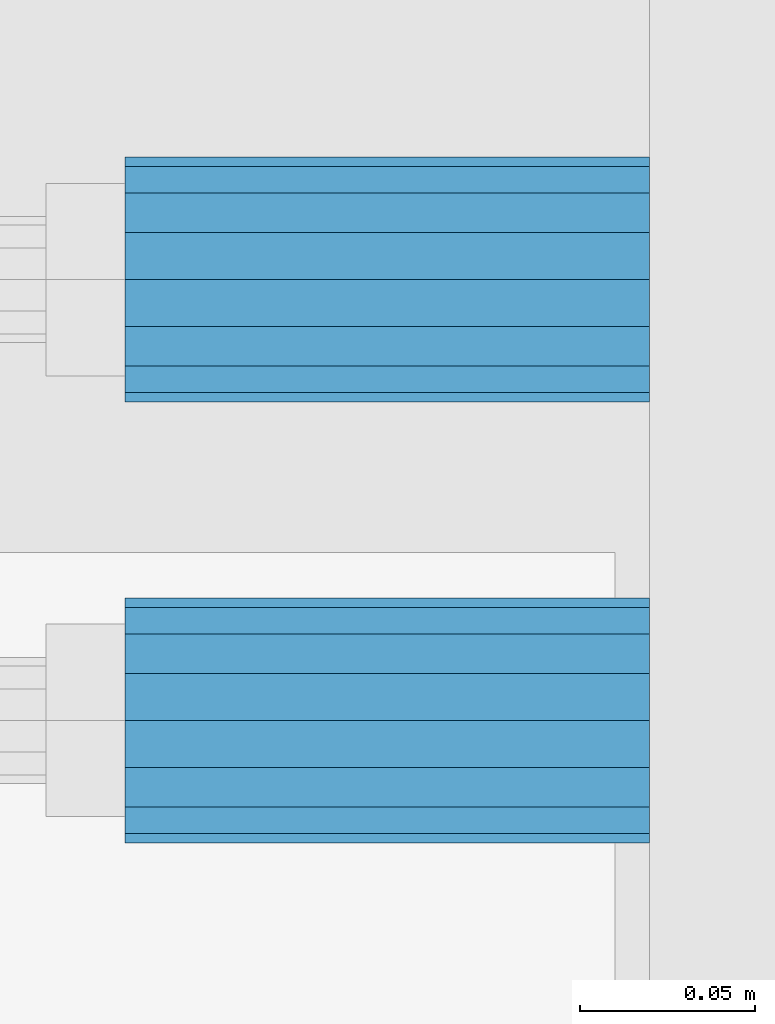
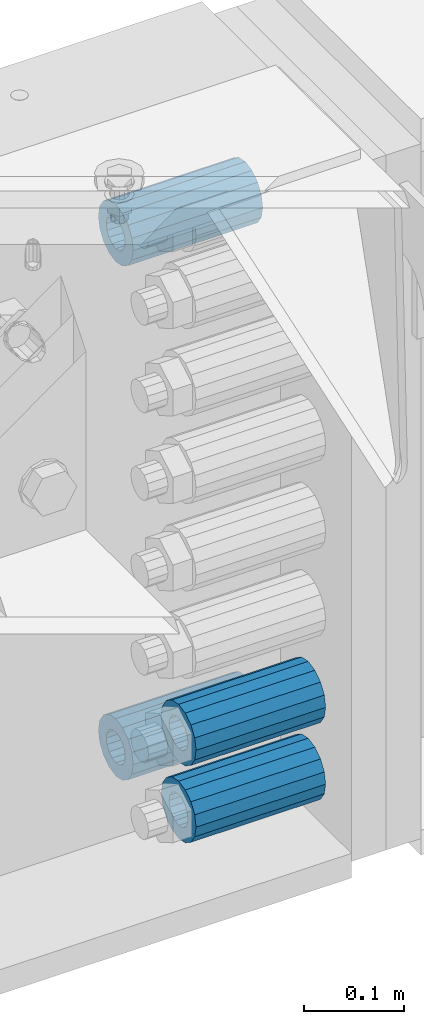
# One storey, part 144 of 208: 4 beams.
"""IFC2X3 building model written with IfcOpenShell, lengths in millimetres."""

from ifc_helpers import new_model, si_unit, frame, origin_with_axes, place, context, subcontext, project, spatial, faceted_brep, material, type_object, element, save


model = new_model("IFC2X3")

# Units and contexts
model_context = context("Model", 3, precision=1e-05, world=origin_with_axes())
body_context = subcontext(model_context, "Body", "Model", "MODEL_VIEW")
ifc_project = project(units=[si_unit("LENGTHUNIT", "METRE", prefix="MILLI"), si_unit("AREAUNIT", "SQUARE_METRE"), si_unit("VOLUMEUNIT", "CUBIC_METRE"), si_unit("MASSUNIT", "GRAM", prefix="KILO"), si_unit("TIMEUNIT", "SECOND"), si_unit("PLANEANGLEUNIT", "RADIAN"), si_unit("SOLIDANGLEUNIT", "STERADIAN"), si_unit("THERMODYNAMICTEMPERATUREUNIT", "DEGREE_CELSIUS"), si_unit("LUMINOUSINTENSITYUNIT", "LUMEN")], contexts=[model_context])

# Site, building, storey
site_placement = place(None, origin_with_axes())
site = spatial("IfcSite", under=ifc_project, at=site_placement, CompositionType="ELEMENT")
building_placement = place(site_placement, origin_with_axes())
building = spatial("IfcBuilding", under=site, at=building_placement, Name="Standard", CompositionType="ELEMENT")
storey_placement = place(building_placement, origin_with_axes())
storey = spatial("IfcBuildingStorey", under=building, at=storey_placement, Name="Undefined", CompositionType="ELEMENT", Elevation=0.0)

# Beams
ifc_material = material()
beam_type = type_object("IfcBeamType", PredefinedType="NOTDEFINED")
beam_1_placement = place(storey_placement, frame((-25783.0, 6063.0, -178.0), z_axis=(0.0, 0.0, 1.0), x_axis=(1.0, 0.0, 0.0)))
element("IfcBeam", 1, at=beam_1_placement, inside=storey, type_object=beam_type, material=ifc_material, context=body_context, shape_type="Brep", body=[
    faceted_brep([(-1.3120632047503e-07, -18.9999999995496, -6.26459950581193e-09), (0.0, -17.5537111177146, 7.27098521493672), (150.0, -17.5537111177146, 7.27098521493672), (150.0, -19.0, 0.0), (0.0, -13.4350288425444, 13.4350288425444), (150.0, -13.4350288425444, 13.4350288425444), (0.0, -7.2709852149369, 17.5537111177144), (150.0, -7.2709852149369, 17.5537111177144), (-6.33906438451959e-09, 4.50199877377599e-10, 18.9999999937354), (150.0, 0.0, 19.0), (0.0, 7.2709852149369, 17.5537111177144), (150.0, 7.2709852149369, 17.5537111177144), (0.0, 13.4350288425444, 13.4350288425444), (150.0, 13.4350288425444, 13.4350288425444), (0.0, 17.5537111177146, 7.2709852149367), (150.0, 17.5537111177146, 7.2709852149367), (1.33208345687308e-07, 19.0000000004507, -6.26459950581193e-09), (150.0, 19.0, 0.0), (0.0, 17.5537111177146, -7.2709852149367), (150.0, 17.5537111177146, -7.2709852149367), (0.0, 13.4350288425444, -13.4350288425444), (150.0, 13.4350288425444, -13.4350288425444), (0.0, 7.2709852149369, -17.5537111177144), (150.0, 7.2709852149369, -17.5537111177144), (8.34120328363497e-09, 4.50427251053043e-10, -19.0000000062646), (150.0, 0.0, -19.0), (0.0, -7.2709852149369, -17.5537111177144), (150.0, -7.2709852149369, -17.5537111177144), (0.0, -13.4350288425444, -13.4350288425444), (150.0, -13.4350288425444, -13.4350288425444), (0.0, -17.5537111177146, -7.2709852149367), (150.0, -17.5537111177146, -7.2709852149367), (0.0, -35.0, 0.0), (-3.63797880709171e-12, -32.335783637895, -13.3939201327782), (150.0, -32.335783637895, -13.3939201327782), (150.0, -35.0, 0.0), (0.0, -24.7487373415292, -24.7487373415291), (150.0, -24.7487373415293, -24.7487373415292), (0.0, -13.3939201327781, -32.335783637895), (150.0, -13.393920132778, -32.335783637895), (0.0, 0.0, -35.0), (150.0, 0.0, -35.0), (0.0, 13.3939201327782, -32.335783637895), (150.0, 13.393920132778, -32.335783637895), (0.0, 24.7487373415292, -24.7487373415291), (150.0, 24.7487373415293, -24.7487373415292), (-3.63797880709171e-12, 32.335783637895, -13.3939201327782), (150.0, 32.335783637895, -13.3939201327781), (0.0, 35.0, 0.0), (150.0, 35.0, 0.0), (0.0, 32.335783637895, 13.3939201327781), (150.0, 32.335783637895, 13.3939201327781), (0.0, 24.7487373415292, 24.748737341529), (150.0, 24.7487373415293, 24.7487373415292), (0.0, 13.3939201327781, 32.335783637895), (150.0, 13.393920132778, 32.335783637895), (-3.63797880709171e-12, 0.0, 35.0), (150.0, 0.0, 35.0), (0.0, -13.3939201327781, 32.335783637895), (150.0, -13.393920132778, 32.335783637895), (0.0, -24.7487373415292, 24.748737341529), (150.0, -24.7487373415293, 24.7487373415292), (0.0, -32.335783637895, 13.3939201327781), (150.0, -32.335783637895, 13.3939201327781)], [[[0, 1, 2, 3]], [[1, 4, 5, 2]], [[4, 6, 7, 5]], [[6, 8, 9, 7]], [[8, 10, 11, 9]], [[10, 12, 13, 11]], [[12, 14, 15, 13]], [[14, 16, 17, 15]], [[16, 18, 19, 17]], [[18, 20, 21, 19]], [[20, 22, 23, 21]], [[22, 24, 25, 23]], [[24, 26, 27, 25]], [[26, 28, 29, 27]], [[28, 30, 31, 29]], [[30, 0, 3, 31]], [[32, 33, 34, 35]], [[33, 36, 37, 34]], [[36, 38, 39, 37]], [[38, 40, 41, 39]], [[40, 42, 43, 41]], [[42, 44, 45, 43]], [[44, 46, 47, 45]], [[46, 48, 49, 47]], [[48, 50, 51, 49]], [[50, 52, 53, 51]], [[52, 54, 55, 53]], [[54, 56, 57, 55]], [[56, 58, 59, 57]], [[58, 60, 61, 59]], [[60, 62, 63, 61]], [[62, 32, 35, 63]], [[37, 39, 41, 43, 45, 47, 49, 51, 53, 55, 57, 59, 61, 63, 35, 34], [5, 7, 9, 11, 13, 15, 17, 19, 21, 23, 25, 27, 29, 31, 3, 2]], [[62, 60, 58, 56, 54, 52, 50, 48, 46, 44, 42, 40, 38, 36, 33, 32], [30, 28, 26, 24, 22, 20, 18, 16, 14, 12, 10, 8, 6, 4, 1, 0]]]),
])
beam_2_placement = place(storey_placement, frame((-25783.0, 5937.0, -713.0), z_axis=(0.0, 0.0, 1.0), x_axis=(1.0, 0.0, 0.0)))
element("IfcBeam", 2, at=beam_2_placement, inside=storey, type_object=beam_type, material=ifc_material, context=body_context, shape_type="Brep", body=[
    faceted_brep([(-1.3120632047503e-07, -18.9999999995496, -6.26459950581193e-09), (0.0, -17.5537111177146, 7.27098521493672), (150.0, -17.5537111177146, 7.27098521493672), (150.0, -19.0, 0.0), (0.0, -13.4350288425444, 13.4350288425444), (150.0, -13.4350288425444, 13.4350288425444), (0.0, -7.2709852149369, 17.5537111177144), (150.0, -7.2709852149369, 17.5537111177144), (-6.33906438451959e-09, 4.50199877377599e-10, 18.9999999937354), (150.0, 0.0, 19.0), (0.0, 7.2709852149369, 17.5537111177144), (150.0, 7.2709852149369, 17.5537111177144), (0.0, 13.4350288425444, 13.4350288425444), (150.0, 13.4350288425444, 13.4350288425444), (0.0, 17.5537111177146, 7.2709852149367), (150.0, 17.5537111177146, 7.2709852149367), (1.33208345687308e-07, 19.0000000004507, -6.26459950581193e-09), (150.0, 19.0, 0.0), (0.0, 17.5537111177146, -7.2709852149367), (150.0, 17.5537111177146, -7.2709852149367), (0.0, 13.4350288425444, -13.4350288425444), (150.0, 13.4350288425444, -13.4350288425444), (0.0, 7.2709852149369, -17.5537111177144), (150.0, 7.2709852149369, -17.5537111177144), (8.34120328363497e-09, 4.50427251053043e-10, -19.0000000062646), (150.0, 0.0, -19.0), (0.0, -7.2709852149369, -17.5537111177144), (150.0, -7.2709852149369, -17.5537111177144), (0.0, -13.4350288425444, -13.4350288425444), (150.0, -13.4350288425444, -13.4350288425444), (0.0, -17.5537111177146, -7.2709852149367), (150.0, -17.5537111177146, -7.2709852149367), (0.0, -35.0, 0.0), (-3.63797880709171e-12, -32.335783637895, -13.3939201327782), (150.0, -32.335783637895, -13.3939201327782), (150.0, -35.0, 0.0), (0.0, -24.7487373415292, -24.7487373415291), (150.0, -24.7487373415293, -24.7487373415292), (0.0, -13.3939201327781, -32.335783637895), (150.0, -13.393920132778, -32.335783637895), (0.0, 0.0, -35.0), (150.0, 0.0, -35.0), (0.0, 13.3939201327782, -32.335783637895), (150.0, 13.393920132778, -32.335783637895), (0.0, 24.7487373415292, -24.7487373415291), (150.0, 24.7487373415293, -24.7487373415292), (-3.63797880709171e-12, 32.335783637895, -13.3939201327782), (150.0, 32.335783637895, -13.3939201327781), (0.0, 35.0, 0.0), (150.0, 35.0, 0.0), (0.0, 32.335783637895, 13.3939201327781), (150.0, 32.335783637895, 13.3939201327781), (0.0, 24.7487373415292, 24.748737341529), (150.0, 24.7487373415293, 24.7487373415292), (0.0, 13.3939201327781, 32.335783637895), (150.0, 13.393920132778, 32.335783637895), (-3.63797880709171e-12, 0.0, 35.0), (150.0, 0.0, 35.0), (0.0, -13.3939201327781, 32.335783637895), (150.0, -13.393920132778, 32.335783637895), (0.0, -24.7487373415292, 24.748737341529), (150.0, -24.7487373415293, 24.7487373415292), (0.0, -32.335783637895, 13.3939201327781), (150.0, -32.335783637895, 13.3939201327781)], [[[0, 1, 2, 3]], [[1, 4, 5, 2]], [[4, 6, 7, 5]], [[6, 8, 9, 7]], [[8, 10, 11, 9]], [[10, 12, 13, 11]], [[12, 14, 15, 13]], [[14, 16, 17, 15]], [[16, 18, 19, 17]], [[18, 20, 21, 19]], [[20, 22, 23, 21]], [[22, 24, 25, 23]], [[24, 26, 27, 25]], [[26, 28, 29, 27]], [[28, 30, 31, 29]], [[30, 0, 3, 31]], [[32, 33, 34, 35]], [[33, 36, 37, 34]], [[36, 38, 39, 37]], [[38, 40, 41, 39]], [[40, 42, 43, 41]], [[42, 44, 45, 43]], [[44, 46, 47, 45]], [[46, 48, 49, 47]], [[48, 50, 51, 49]], [[50, 52, 53, 51]], [[52, 54, 55, 53]], [[54, 56, 57, 55]], [[56, 58, 59, 57]], [[58, 60, 61, 59]], [[60, 62, 63, 61]], [[62, 32, 35, 63]], [[37, 39, 41, 43, 45, 47, 49, 51, 53, 55, 57, 59, 61, 63, 35, 34], [5, 7, 9, 11, 13, 15, 17, 19, 21, 23, 25, 27, 29, 31, 3, 2]], [[62, 60, 58, 56, 54, 52, 50, 48, 46, 44, 42, 40, 38, 36, 33, 32], [30, 28, 26, 24, 22, 20, 18, 16, 14, 12, 10, 8, 6, 4, 1, 0]]]),
])
beam_3_placement = place(storey_placement, frame((-25783.0, 6063.0, -807.0), z_axis=(0.0, 0.0, 1.0), x_axis=(1.0, 0.0, 0.0)))
element("IfcBeam", 3, at=beam_3_placement, inside=storey, type_object=beam_type, material=ifc_material, context=body_context, shape_type="Brep", body=[
    faceted_brep([(-1.3120632047503e-07, -18.9999999995496, -6.26459950581193e-09), (0.0, -17.5537111177146, 7.27098521493672), (150.0, -17.5537111177146, 7.27098521493672), (150.0, -19.0, 0.0), (0.0, -13.4350288425444, 13.4350288425444), (150.0, -13.4350288425444, 13.4350288425444), (0.0, -7.2709852149369, 17.5537111177144), (150.0, -7.2709852149369, 17.5537111177144), (-6.33906438451959e-09, 4.50199877377599e-10, 18.9999999937354), (150.0, 0.0, 19.0), (0.0, 7.2709852149369, 17.5537111177144), (150.0, 7.2709852149369, 17.5537111177144), (0.0, 13.4350288425444, 13.4350288425444), (150.0, 13.4350288425444, 13.4350288425444), (0.0, 17.5537111177146, 7.2709852149367), (150.0, 17.5537111177146, 7.2709852149367), (1.33208345687308e-07, 19.0000000004507, -6.26459950581193e-09), (150.0, 19.0, 0.0), (0.0, 17.5537111177146, -7.2709852149367), (150.0, 17.5537111177146, -7.2709852149367), (0.0, 13.4350288425444, -13.4350288425444), (150.0, 13.4350288425444, -13.4350288425444), (0.0, 7.2709852149369, -17.5537111177144), (150.0, 7.2709852149369, -17.5537111177144), (8.34120328363497e-09, 4.50427251053043e-10, -19.0000000062646), (150.0, 0.0, -19.0), (0.0, -7.2709852149369, -17.5537111177144), (150.0, -7.2709852149369, -17.5537111177144), (0.0, -13.4350288425444, -13.4350288425444), (150.0, -13.4350288425444, -13.4350288425444), (0.0, -17.5537111177146, -7.2709852149367), (150.0, -17.5537111177146, -7.2709852149367), (0.0, -35.0, 0.0), (-3.63797880709171e-12, -32.335783637895, -13.3939201327782), (150.0, -32.335783637895, -13.3939201327782), (150.0, -35.0, 0.0), (0.0, -24.7487373415292, -24.7487373415291), (150.0, -24.7487373415293, -24.7487373415292), (0.0, -13.3939201327781, -32.335783637895), (150.0, -13.393920132778, -32.335783637895), (0.0, 0.0, -35.0), (150.0, 0.0, -35.0), (0.0, 13.3939201327782, -32.335783637895), (150.0, 13.393920132778, -32.335783637895), (0.0, 24.7487373415292, -24.7487373415291), (150.0, 24.7487373415293, -24.7487373415292), (-3.63797880709171e-12, 32.335783637895, -13.3939201327782), (150.0, 32.335783637895, -13.3939201327781), (0.0, 35.0, 0.0), (150.0, 35.0, 0.0), (0.0, 32.335783637895, 13.3939201327781), (150.0, 32.335783637895, 13.3939201327781), (0.0, 24.7487373415292, 24.748737341529), (150.0, 24.7487373415293, 24.7487373415292), (0.0, 13.3939201327781, 32.335783637895), (150.0, 13.393920132778, 32.335783637895), (-3.63797880709171e-12, 0.0, 35.0), (150.0, 0.0, 35.0), (0.0, -13.3939201327781, 32.335783637895), (150.0, -13.393920132778, 32.335783637895), (0.0, -24.7487373415292, 24.748737341529), (150.0, -24.7487373415293, 24.7487373415292), (0.0, -32.335783637895, 13.3939201327781), (150.0, -32.335783637895, 13.3939201327781)], [[[0, 1, 2, 3]], [[1, 4, 5, 2]], [[4, 6, 7, 5]], [[6, 8, 9, 7]], [[8, 10, 11, 9]], [[10, 12, 13, 11]], [[12, 14, 15, 13]], [[14, 16, 17, 15]], [[16, 18, 19, 17]], [[18, 20, 21, 19]], [[20, 22, 23, 21]], [[22, 24, 25, 23]], [[24, 26, 27, 25]], [[26, 28, 29, 27]], [[28, 30, 31, 29]], [[30, 0, 3, 31]], [[32, 33, 34, 35]], [[33, 36, 37, 34]], [[36, 38, 39, 37]], [[38, 40, 41, 39]], [[40, 42, 43, 41]], [[42, 44, 45, 43]], [[44, 46, 47, 45]], [[46, 48, 49, 47]], [[48, 50, 51, 49]], [[50, 52, 53, 51]], [[52, 54, 55, 53]], [[54, 56, 57, 55]], [[56, 58, 59, 57]], [[58, 60, 61, 59]], [[60, 62, 63, 61]], [[62, 32, 35, 63]], [[37, 39, 41, 43, 45, 47, 49, 51, 53, 55, 57, 59, 61, 63, 35, 34], [5, 7, 9, 11, 13, 15, 17, 19, 21, 23, 25, 27, 29, 31, 3, 2]], [[62, 60, 58, 56, 54, 52, 50, 48, 46, 44, 42, 40, 38, 36, 33, 32], [30, 28, 26, 24, 22, 20, 18, 16, 14, 12, 10, 8, 6, 4, 1, 0]]]),
])
beam_4_placement = place(storey_placement, frame((-25783.0, 5937.0, -807.0), z_axis=(0.0, 0.0, 1.0), x_axis=(1.0, 0.0, 0.0)))
element("IfcBeam", 4, at=beam_4_placement, inside=storey, type_object=beam_type, material=ifc_material, context=body_context, shape_type="Brep", body=[
    faceted_brep([(-1.3120632047503e-07, -18.9999999995496, -6.26459950581193e-09), (0.0, -17.5537111177146, 7.27098521493672), (150.0, -17.5537111177146, 7.27098521493672), (150.0, -19.0, 0.0), (0.0, -13.4350288425444, 13.4350288425444), (150.0, -13.4350288425444, 13.4350288425444), (0.0, -7.2709852149369, 17.5537111177144), (150.0, -7.2709852149369, 17.5537111177144), (-6.33906438451959e-09, 4.50199877377599e-10, 18.9999999937354), (150.0, 0.0, 19.0), (0.0, 7.2709852149369, 17.5537111177144), (150.0, 7.2709852149369, 17.5537111177144), (0.0, 13.4350288425444, 13.4350288425444), (150.0, 13.4350288425444, 13.4350288425444), (0.0, 17.5537111177146, 7.2709852149367), (150.0, 17.5537111177146, 7.2709852149367), (1.33208345687308e-07, 19.0000000004507, -6.26459950581193e-09), (150.0, 19.0, 0.0), (0.0, 17.5537111177146, -7.2709852149367), (150.0, 17.5537111177146, -7.2709852149367), (0.0, 13.4350288425444, -13.4350288425444), (150.0, 13.4350288425444, -13.4350288425444), (0.0, 7.2709852149369, -17.5537111177144), (150.0, 7.2709852149369, -17.5537111177144), (8.34120328363497e-09, 4.50427251053043e-10, -19.0000000062646), (150.0, 0.0, -19.0), (0.0, -7.2709852149369, -17.5537111177144), (150.0, -7.2709852149369, -17.5537111177144), (0.0, -13.4350288425444, -13.4350288425444), (150.0, -13.4350288425444, -13.4350288425444), (0.0, -17.5537111177146, -7.2709852149367), (150.0, -17.5537111177146, -7.2709852149367), (0.0, -35.0, 0.0), (-3.63797880709171e-12, -32.335783637895, -13.3939201327782), (150.0, -32.335783637895, -13.3939201327782), (150.0, -35.0, 0.0), (0.0, -24.7487373415292, -24.7487373415291), (150.0, -24.7487373415293, -24.7487373415292), (0.0, -13.3939201327781, -32.335783637895), (150.0, -13.393920132778, -32.335783637895), (0.0, 0.0, -35.0), (150.0, 0.0, -35.0), (0.0, 13.3939201327782, -32.335783637895), (150.0, 13.393920132778, -32.335783637895), (0.0, 24.7487373415292, -24.7487373415291), (150.0, 24.7487373415293, -24.7487373415292), (-3.63797880709171e-12, 32.335783637895, -13.3939201327782), (150.0, 32.335783637895, -13.3939201327781), (0.0, 35.0, 0.0), (150.0, 35.0, 0.0), (0.0, 32.335783637895, 13.3939201327781), (150.0, 32.335783637895, 13.3939201327781), (0.0, 24.7487373415292, 24.748737341529), (150.0, 24.7487373415293, 24.7487373415292), (0.0, 13.3939201327781, 32.335783637895), (150.0, 13.393920132778, 32.335783637895), (-3.63797880709171e-12, 0.0, 35.0), (150.0, 0.0, 35.0), (0.0, -13.3939201327781, 32.335783637895), (150.0, -13.393920132778, 32.335783637895), (0.0, -24.7487373415292, 24.748737341529), (150.0, -24.7487373415293, 24.7487373415292), (0.0, -32.335783637895, 13.3939201327781), (150.0, -32.335783637895, 13.3939201327781)], [[[0, 1, 2, 3]], [[1, 4, 5, 2]], [[4, 6, 7, 5]], [[6, 8, 9, 7]], [[8, 10, 11, 9]], [[10, 12, 13, 11]], [[12, 14, 15, 13]], [[14, 16, 17, 15]], [[16, 18, 19, 17]], [[18, 20, 21, 19]], [[20, 22, 23, 21]], [[22, 24, 25, 23]], [[24, 26, 27, 25]], [[26, 28, 29, 27]], [[28, 30, 31, 29]], [[30, 0, 3, 31]], [[32, 33, 34, 35]], [[33, 36, 37, 34]], [[36, 38, 39, 37]], [[38, 40, 41, 39]], [[40, 42, 43, 41]], [[42, 44, 45, 43]], [[44, 46, 47, 45]], [[46, 48, 49, 47]], [[48, 50, 51, 49]], [[50, 52, 53, 51]], [[52, 54, 55, 53]], [[54, 56, 57, 55]], [[56, 58, 59, 57]], [[58, 60, 61, 59]], [[60, 62, 63, 61]], [[62, 32, 35, 63]], [[37, 39, 41, 43, 45, 47, 49, 51, 53, 55, 57, 59, 61, 63, 35, 34], [5, 7, 9, 11, 13, 15, 17, 19, 21, 23, 25, 27, 29, 31, 3, 2]], [[62, 60, 58, 56, 54, 52, 50, 48, 46, 44, 42, 40, 38, 36, 33, 32], [30, 28, 26, 24, 22, 20, 18, 16, 14, 12, 10, 8, 6, 4, 1, 0]]]),
])

save(model, "model.ifc")
